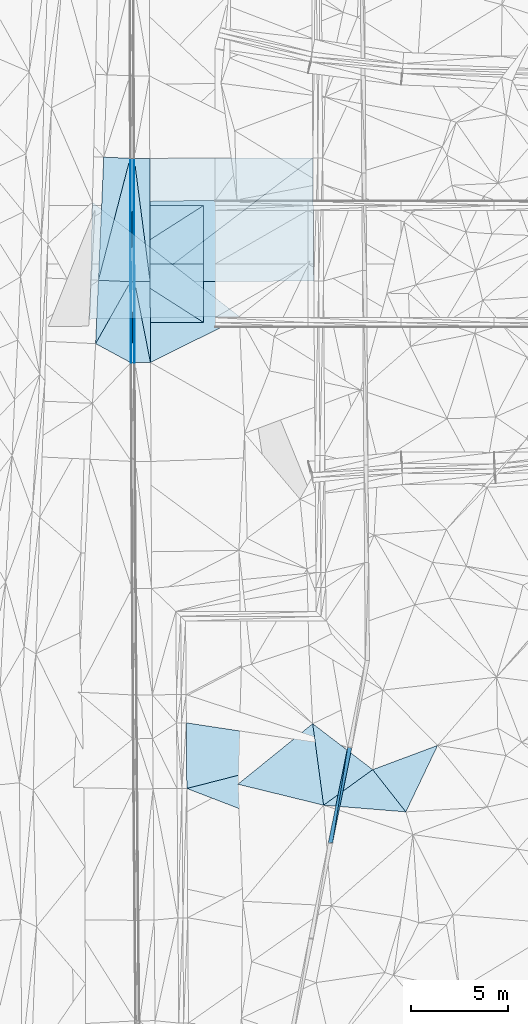
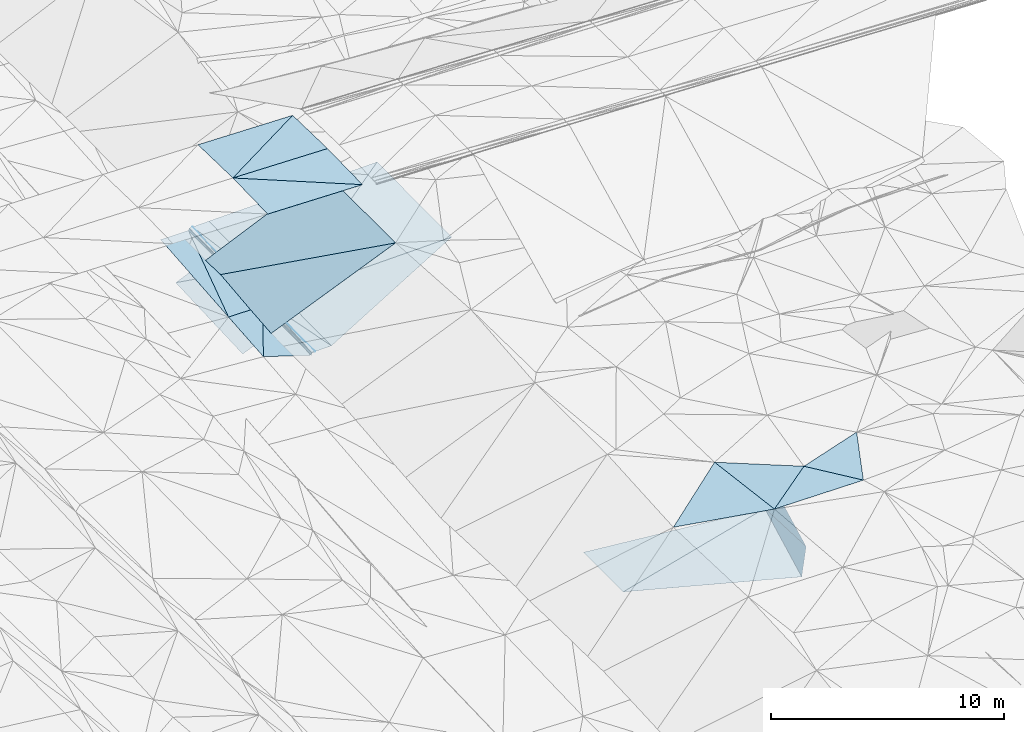
# One storey, part 97 of 275: 37 plates.
"""IFC2X3 building model written with IfcOpenShell, lengths in millimetres."""

from ifc_helpers import new_model, si_unit, frame, origin_with_axes, place, context, subcontext, project, spatial, polyline, outline, extrude, material, type_object, element, save


model = new_model("IFC2X3")

# Units and contexts
model_context = context("Model", 3, precision=1e-05, world=origin_with_axes())
body_context = subcontext(model_context, "Body", "Model", "MODEL_VIEW")
ifc_project = project(units=[si_unit("LENGTHUNIT", "METRE", prefix="MILLI"), si_unit("AREAUNIT", "SQUARE_METRE"), si_unit("VOLUMEUNIT", "CUBIC_METRE"), si_unit("MASSUNIT", "GRAM", prefix="KILO"), si_unit("TIMEUNIT", "SECOND"), si_unit("PLANEANGLEUNIT", "RADIAN"), si_unit("SOLIDANGLEUNIT", "STERADIAN"), si_unit("THERMODYNAMICTEMPERATUREUNIT", "DEGREE_CELSIUS"), si_unit("LUMINOUSINTENSITYUNIT", "LUMEN")], contexts=[model_context])

# Site, building, storey
site_placement = place(None, origin_with_axes())
site = spatial("IfcSite", under=ifc_project, at=site_placement, CompositionType="ELEMENT")
building_placement = place(site_placement, origin_with_axes())
building = spatial("IfcBuilding", under=site, at=building_placement, Name="Undefined", CompositionType="ELEMENT")
storey_placement = place(building_placement, origin_with_axes())
storey = spatial("IfcBuildingStorey", under=building, at=storey_placement, Name="Undefined", CompositionType="ELEMENT", Elevation=0.0)

# Plates
ifc_material = material()
plate_type_1 = type_object("IfcPlateType", PredefinedType="NOTDEFINED")
plate_1_placement = place(storey_placement, frame((-46443.3238897026, 38495.5351845441, 42288.5672650647), z_axis=(0.971991965512378, -0.187664425254864, -0.141469722814266), x_axis=(0.13983122705196, -0.0220094670118286, 0.989930710354517)))
element("IfcPlate", 1, at=plate_1_placement, inside=storey, type_object=plate_type_1, material=ifc_material, Name="00_PR", context=body_context, shape_type="SweptSolid", body=[
    extrude(outline(polyline([(0.0, 0.0), (1515.26257324219, -3.74348019249737e-09), (1212.72692871094, 4952.72412109375), (0.0, 0.0)])), frame((-8.85201319254618e-08, 2.18876761149539e-07, -0.5000001331573), z_axis=(0.0, 0.0, 1.0), x_axis=(1.0, 0.0, 0.0)), (0.0, 0.0, 1.0), 1.0),
])
plate_type_2 = type_object("IfcPlateType", PredefinedType="NOTDEFINED")
plate_2_placement = place(storey_placement, frame((-47435.0792210354, 33594.8791324739, 42010.0176847944), z_axis=(0.97139177371509, -0.188361786243016, -0.144630077929844), x_axis=(0.198043906974716, 0.978613638868407, 0.0556233469949972)))
element("IfcPlate", 2, at=plate_2_placement, inside=storey, type_object=plate_type_2, material=ifc_material, Name="00_PR", context=body_context, shape_type="SweptSolid", body=[
    extrude(outline(polyline([(0.0, 0.0), (5007.75341796875, 1.73531589098275e-09), (138.560333251953, 1513.65197753906), (0.0, 0.0)])), frame((-8.85201319254618e-08, 2.18876761149539e-07, -0.5000001331573), z_axis=(0.0, 0.0, 1.0), x_axis=(1.0, 0.0, 0.0)), (0.0, 0.0, 1.0), 1.0),
])
plate_type_3 = type_object("IfcPlateType", PredefinedType="NOTDEFINED")
plate_3_placement = place(storey_placement, frame((-46443.8034789275, 38495.6560898855, 42288.1387737857), z_axis=(0.0128247435438825, 0.0541554654728636, -0.99845015474607), x_axis=(-0.198043906939524, -0.978613638873617, -0.0556233470286216)))
element("IfcPlate", 3, at=plate_3_placement, inside=storey, type_object=plate_type_3, material=ifc_material, Name="00_PR", context=body_context, shape_type="SweptSolid", body=[
    extrude(outline(polyline([(0.0, 0.0), (5007.75341796875, 1.73531589098275e-09), (3712.27709960938, 7666.49609375), (0.0, 0.0)])), frame((-8.85201319254618e-08, 2.18876761149539e-07, -0.5000001331573), z_axis=(0.0, 0.0, 1.0), x_axis=(1.0, 0.0, 0.0)), (0.0, 0.0, 1.0), 1.0),
])
plate_type_4 = type_object("IfcPlateType", PredefinedType="NOTDEFINED")
plate_4_placement = place(storey_placement, frame((-54717.1743218252, 39751.7977095804, 42114.799182884), z_axis=(0.0230936484077741, 0.0141598385852141, -0.999633023851483), x_axis=(0.988457050789085, -0.150079218943008, 0.0207095820045218)))
element("IfcPlate", 4, at=plate_4_placement, inside=storey, type_object=plate_type_4, material=ifc_material, Name="00_PR", context=body_context, shape_type="SweptSolid", body=[
    extrude(outline(polyline([(0.0, 0.0), (8369.990234375, 2.26027623284608e-08), (528.333984375, 3326.34765625), (0.0, 0.0)])), frame((-8.85201319254618e-08, 2.18876761149539e-07, -0.5000001331573), z_axis=(0.0, 0.0, 1.0), x_axis=(1.0, 0.0, 0.0)), (0.0, 0.0, 1.0), 1.0),
])
plate_type_5 = type_object("IfcPlateType", PredefinedType="NOTDEFINED")
plate_5_placement = place(storey_placement, frame((-57583.1580913611, 62381.0842321567, 42323.0437305526), z_axis=(0.970109415832646, 0.00784634959025921, -0.242541040054978), x_axis=(0.00167557597928032, 0.999236718816342, 0.0390278389651242)))
element("IfcPlate", 5, at=plate_5_placement, inside=storey, type_object=plate_type_5, material=ifc_material, Name="00_PR", context=body_context, shape_type="SweptSolid", body=[
    extrude(outline(polyline([(0.0, 0.0), (6334.068359375, 1.19871401693672e-08), (2.44763946533203, 123.643424987793), (0.0, 0.0)])), frame((-8.85201319254618e-08, 2.18876761149539e-07, -0.5000001331573), z_axis=(0.0, 0.0, 1.0), x_axis=(1.0, 0.0, 0.0)), (0.0, 0.0, 1.0), 1.0),
])
plate_6_placement = place(storey_placement, frame((-57553.1504152899, 62378.7984943262, 42442.993732564), z_axis=(0.970109178269229, 0.00792146438474166, -0.242539548609713), x_axis=(-0.00328523098590343, -0.998946768808441, -0.0457663669581172)))
element("IfcPlate", 6, at=plate_6_placement, inside=storey, type_object=plate_type_5, material=ifc_material, Name="00_PR", context=body_context, shape_type="SweptSolid", body=[
    extrude(outline(polyline([(0.0, 0.0), (4155.2783203125, -3.98358679376543e-09), (3.30489063262939, 123.623481750488), (0.0, 0.0)])), frame((-8.85201319254618e-08, 2.18876761149539e-07, -0.5000001331573), z_axis=(0.0, 0.0, 1.0), x_axis=(1.0, 0.0, 0.0)), (0.0, 0.0, 1.0), 1.0),
])
plate_7_placement = place(storey_placement, frame((-57602.5474534094, 68713.4947868656, 42450.3147632828), z_axis=(0.970125228512707, 0.00784385599563176, -0.242477864817158), x_axis=(0.242600788007672, -0.0256887069750325, 0.969786032066872)))
element("IfcPlate", 7, at=plate_7_placement, inside=storey, type_object=plate_type_5, material=ifc_material, Name="00_PR", context=body_context, shape_type="SweptSolid", body=[
    extrude(outline(polyline([(0.0, 0.0), (123.67057800293, -4.36557456851006e-10), (43.9496803283691, 6333.56640625), (0.0, 0.0)])), frame((-8.85201319254618e-08, 2.18876761149539e-07, -0.5000001331573), z_axis=(0.0, 0.0, 1.0), x_axis=(1.0, 0.0, 0.0)), (0.0, 0.0, 1.0), 1.0),
])
plate_type_6 = type_object("IfcPlateType", PredefinedType="NOTDEFINED")
plate_8_placement = place(storey_placement, frame((-57403.6359865546, 62379.214471116, 42442.6150741335), z_axis=(-4.64282948207224e-05, 0.016925120368047, -0.999856758813452), x_axis=(-0.0321763959872276, -0.999339065058416, -0.0169148629744489)))
element("IfcPlate", 8, at=plate_8_placement, inside=storey, type_object=plate_type_6, material=ifc_material, Name="00_PR", context=body_context, shape_type="SweptSolid", body=[
    extrude(outline(polyline([(0.0, 0.0), (4153.7431640625, 9.57516022026539e-09), (5.23764801025391, 149.908599853516), (0.0, 0.0)])), frame((-8.85201319254618e-08, 2.18876761149539e-07, -0.5000001331573), z_axis=(0.0, 0.0, 1.0), x_axis=(1.0, 0.0, 0.0)), (0.0, 0.0, 1.0), 1.0),
])
plate_9_placement = place(storey_placement, frame((-57423.02381466, 68710.2233984152, 42569.8701035571), z_axis=(1.3473543658177e-05, 0.0200946338517407, -0.999798082369049), x_axis=(-0.0206205769656723, -0.999585493107628, -0.0200906389739794)))
element("IfcPlate", 9, at=plate_9_placement, inside=storey, type_object=plate_type_6, material=ifc_material, Name="00_PR", context=body_context, shape_type="SweptSolid", body=[
    extrude(outline(polyline([(0.0, 0.0), (6334.04443359375, -1.89174897968769e-08), (2.99267792701721, 149.976287841797), (0.0, 0.0)])), frame((-8.85201319254618e-08, 2.18876761149539e-07, -0.5000001331573), z_axis=(0.0, 0.0, 1.0), x_axis=(1.0, 0.0, 0.0)), (0.0, 0.0, 1.0), 1.0),
])
plate_10_placement = place(storey_placement, frame((-57553.6354985413, 62378.8045805824, 42442.615103797), z_axis=(-5.51267280488613e-05, 0.0200960484179308, -0.999798052508119), x_axis=(0.0206205769630277, 0.999585493107631, 0.0200906389765653)))
element("IfcPlate", 10, at=plate_10_placement, inside=storey, type_object=plate_type_6, material=ifc_material, Name="00_PR", context=body_context, shape_type="SweptSolid", body=[
    extrude(outline(polyline([(0.0, 0.0), (6334.04443359375, -1.89174897968769e-08), (3.50438213348389, 149.959136962891), (0.0, 0.0)])), frame((-8.85201319254618e-08, 2.18876761149539e-07, -0.5000001331573), z_axis=(0.0, 0.0, 1.0), x_axis=(1.0, 0.0, 0.0)), (0.0, 0.0, 1.0), 1.0),
])
plate_11_placement = place(storey_placement, frame((-57537.2884837733, 58228.2164305022, 42372.3550744703), z_axis=(-5.15273774666968e-05, 0.0169252844974001, -0.999856755785353), x_axis=(0.0321763959547341, 0.999339065059428, 0.0169148629764597)))
element("IfcPlate", 11, at=plate_11_placement, inside=storey, type_object=plate_type_6, material=ifc_material, Name="00_PR", context=body_context, shape_type="SweptSolid", body=[
    extrude(outline(polyline([(0.0, 0.0), (4153.7431640625, 9.57516022026539e-09), (5.28282499313354, 149.907943725586), (0.0, 0.0)])), frame((-8.85201319254618e-08, 2.18876761149539e-07, -0.5000001331573), z_axis=(0.0, 0.0, 1.0), x_axis=(1.0, 0.0, 0.0)), (0.0, 0.0, 1.0), 1.0),
])
plate_type_7 = type_object("IfcPlateType", PredefinedType="NOTDEFINED")
plate_12_placement = place(storey_placement, frame((-57393.0137184063, 68710.2992671655, 42570.4702018794), z_axis=(0.0199409265172803, 0.0201533647620277, -0.99959801987519), x_axis=(0.00306177402900717, -0.999793362311022, -0.0200962239890106)))
element("IfcPlate", 12, at=plate_12_placement, inside=storey, type_object=plate_type_7, material=ifc_material, Name="00_PR", context=body_context, shape_type="SweptSolid", body=[
    extrude(outline(polyline([(0.0, 0.0), (6332.2841796875, -4.51836967840791e-09), (-0.00397421419620514, 30.0062274932861), (0.0, 0.0)])), frame((-8.85201319254618e-08, 2.18876761149539e-07, -0.5000001331573), z_axis=(0.0, 0.0, 1.0), x_axis=(1.0, 0.0, 0.0)), (0.0, 0.0, 1.0), 1.0),
])
plate_13_placement = place(storey_placement, frame((-57373.6257019112, 62379.3221283194, 42443.2151726145), z_axis=(0.0199319540919098, 0.0170006912218534, -0.999656787954775), x_axis=(0.00393805502764794, -0.999848999201306, -0.0169254399867523)))
element("IfcPlate", 13, at=plate_13_placement, inside=storey, type_object=plate_type_7, material=ifc_material, Name="00_PR", context=body_context, shape_type="SweptSolid", body=[
    extrude(outline(polyline([(0.0, 0.0), (4151.1474609375, 2.19733919948339e-09), (-0.000386318599339575, 30.0064868927002), (0.0, 0.0)])), frame((-8.85201319254618e-08, 2.18876761149539e-07, -0.5000001331573), z_axis=(0.0, 0.0, 1.0), x_axis=(1.0, 0.0, 0.0)), (0.0, 0.0, 1.0), 1.0),
])
plate_14_placement = place(storey_placement, frame((-57403.6260058779, 62379.2160860442, 42442.6152035022), z_axis=(0.0199197102945719, 0.0201533083165192, -0.999598444029241), x_axis=(-0.00306177403052617, 0.999793362310987, 0.0200962239905203)))
element("IfcPlate", 14, at=plate_14_placement, inside=storey, type_object=plate_type_7, material=ifc_material, Name="00_PR", context=body_context, shape_type="SweptSolid", body=[
    extrude(outline(polyline([(0.0, 0.0), (6332.31591796875, 6.03904481977224e-10), (0.0278000384569168, 30.0064754486084), (0.0, 0.0)])), frame((-8.85201319254618e-08, 2.18876761149539e-07, -0.5000001331573), z_axis=(0.0, 0.0, 1.0), x_axis=(1.0, 0.0, 0.0)), (0.0, 0.0, 1.0), 1.0),
])
plate_15_placement = place(storey_placement, frame((-57387.2781938566, 58228.6731262315, 42372.3551743168), z_axis=(0.0199204725202809, 0.0170006498874618, -0.999657017520496), x_axis=(-0.00393805503277825, 0.999848999201264, 0.0169254399880597)))
element("IfcPlate", 15, at=plate_15_placement, inside=storey, type_object=plate_type_7, material=ifc_material, Name="00_PR", context=body_context, shape_type="SweptSolid", body=[
    extrude(outline(polyline([(0.0, 0.0), (4151.16796875, 1.2019881978631e-08), (0.0202217120677233, 30.006196975708), (0.0, 0.0)])), frame((-8.85201319254618e-08, 2.18876761149539e-07, -0.5000001331573), z_axis=(0.0, 0.0, 1.0), x_axis=(1.0, 0.0, 0.0)), (0.0, 0.0, 1.0), 1.0),
])
plate_type_8 = type_object("IfcPlateType", PredefinedType="NOTDEFINED")
plate_16_placement = place(storey_placement, frame((-57603.0168962329, 68713.5009297058, 42449.9363460204), z_axis=(0.0312264402809084, 0.0201291176493456, -0.999309625716695), x_axis=(-0.251028639082119, -0.967593640171282, -0.0273344079991938)))
element("IfcPlate", 16, at=plate_16_placement, inside=storey, type_object=plate_type_8, material=ifc_material, Name="00_PR", context=body_context, shape_type="SweptSolid", body=[
    extrude(outline(polyline([(0.0, 0.0), (6468.66015625, -3.15776560455561e-09), (284.202697753906, 1322.8330078125), (0.0, 0.0)])), frame((-8.85201319254618e-08, 2.18876761149539e-07, -0.5000001331573), z_axis=(0.0, 0.0, 1.0), x_axis=(1.0, 0.0, 0.0)), (0.0, 0.0, 1.0), 1.0),
])
plate_type_9 = type_object("IfcPlateType", PredefinedType="NOTDEFINED")
plate_17_placement = place(storey_placement, frame((-59226.8359766766, 62454.4664118269, 42273.1193435285), z_axis=(0.0310324259714085, 0.0201795939242266, -0.999314651412348), x_axis=(0.25102863907814, 0.967593640172316, 0.0273344079991539)))
element("IfcPlate", 17, at=plate_17_placement, inside=storey, type_object=plate_type_9, material=ifc_material, Name="00_PR", context=body_context, shape_type="SweptSolid", body=[
    extrude(outline(polyline([(0.0, 0.0), (6468.66015625, -3.15776560455561e-09), (342.848510742188, 1609.48046875), (0.0, 0.0)])), frame((-8.85201319254618e-08, 2.18876761149539e-07, -0.5000001331573), z_axis=(0.0, 0.0, 1.0), x_axis=(1.0, 0.0, 0.0)), (0.0, 0.0, 1.0), 1.0),
])
plate_type_10 = type_object("IfcPlateType", PredefinedType="NOTDEFINED")
plate_18_placement = place(storey_placement, frame((-57583.627696025, 62381.0888398174, 42322.6653124448), z_axis=(0.0308951552232483, 0.0170634038894143, -0.999376970732985), x_axis=(-0.490203292960482, -0.871090745870499, -0.0300273879896106)))
element("IfcPlate", 18, at=plate_18_placement, inside=storey, type_object=plate_type_10, material=ifc_material, Name="00_PR", context=body_context, shape_type="SweptSolid", body=[
    extrude(outline(polyline([(0.0, 0.0), (3648.26953125, -7.97444954514503e-09), (743.076721191406, 1468.267578125), (0.0, 0.0)])), frame((-8.85201319254618e-08, 2.18876761149539e-07, -0.5000001331573), z_axis=(0.0, 0.0, 1.0), x_axis=(1.0, 0.0, 0.0)), (0.0, 0.0, 1.0), 1.0),
])
plate_type_11 = type_object("IfcPlateType", PredefinedType="NOTDEFINED")
plate_19_placement = place(storey_placement, frame((-48224.0877429359, 68733.5261889492, 42753.8472018296), z_axis=(0.0199193965717795, 0.0201840669271931, -0.999597829670761), x_axis=(0.00717806702355623, -0.999773319631286, -0.0200445680233559)))
element("IfcPlate", 19, at=plate_19_placement, inside=storey, type_object=plate_type_11, material=ifc_material, Name="00_PR", context=body_context, shape_type="SweptSolid", body=[
    extrude(outline(polyline([(0.0, 0.0), (6322.611328125, 2.99114617519081e-08), (6295.85986328125, 8396.619140625), (0.0, 0.0)])), frame((-8.85201319254618e-08, 2.18876761149539e-07, -0.5000001331573), z_axis=(0.0, 0.0, 1.0), x_axis=(1.0, 0.0, 0.0)), (0.0, 0.0, 1.0), 1.0),
])
plate_type_12 = type_object("IfcPlateType", PredefinedType="NOTDEFINED")
plate_20_placement = place(storey_placement, frame((-56593.0162378937, 68712.3262125957, 42586.4702020143), z_axis=(0.0199409537790838, 0.0201560509080303, -0.999597965171085), x_axis=(0.00306180399194172, -0.999793308226059, -0.0200989099880669)))
element("IfcPlate", 20, at=plate_20_placement, inside=storey, type_object=plate_type_12, material=ifc_material, Name="00_PR", context=body_context, shape_type="SweptSolid", body=[
    extrude(outline(polyline([(0.0, 0.0), (6331.43798828125, -4.45434125140309e-08), (-0.101329416036606, 800.160034179688), (0.0, 0.0)])), frame((-8.85201319254618e-08, 2.18876761149539e-07, -0.5000001331573), z_axis=(0.0, 0.0, 1.0), x_axis=(1.0, 0.0, 0.0)), (0.0, 0.0, 1.0), 1.0),
])
plate_21_placement = place(storey_placement, frame((-56573.6306226574, 62382.1953694276, 42459.2151729288), z_axis=(0.0199321903594171, 0.0170029528414679, -0.999656744779), x_axis=(0.00393791499498568, -0.999848961425214, -0.0169277039911789)))
element("IfcPlate", 21, at=plate_21_placement, inside=storey, type_object=plate_type_12, material=ifc_material, Name="00_PR", context=body_context, shape_type="SweptSolid", body=[
    extrude(outline(polyline([(0.0, 0.0), (4150.59228515625, 1.087028067559e-08), (-0.00666399206966162, 800.160217285156), (0.0, 0.0)])), frame((-8.85201319254618e-08, 2.18876761149539e-07, -0.5000001331573), z_axis=(0.0, 0.0, 1.0), x_axis=(1.0, 0.0, 0.0)), (0.0, 0.0, 1.0), 1.0),
])
plate_22_placement = place(storey_placement, frame((-57373.6257084057, 62379.3237044941, 42443.2152018937), z_axis=(0.0199197102945719, 0.0201533083165192, -0.999598444029241), x_axis=(-0.00306177403052617, 0.999793362310987, 0.0200962239905203)))
element("IfcPlate", 22, at=plate_22_placement, inside=storey, type_object=plate_type_12, material=ifc_material, Name="00_PR", context=body_context, shape_type="SweptSolid", body=[
    extrude(outline(polyline([(0.0, 0.0), (6332.2841796875, -4.51836967840791e-09), (0.744781196117401, 800.159851074219), (0.0, 0.0)])), frame((-8.85201319254618e-08, 2.18876761149539e-07, -0.5000001331573), z_axis=(0.0, 0.0, 1.0), x_axis=(1.0, 0.0, 0.0)), (0.0, 0.0, 1.0), 1.0),
])
plate_23_placement = place(storey_placement, frame((-57357.2782605059, 58228.8013939178, 42372.955173437), z_axis=(0.0199204725202809, 0.0170006498874618, -0.999657017520496), x_axis=(-0.00393805503277825, 0.999848999201264, 0.0169254399880597)))
element("IfcPlate", 23, at=plate_23_placement, inside=storey, type_object=plate_type_12, material=ifc_material, Name="00_PR", context=body_context, shape_type="SweptSolid", body=[
    extrude(outline(polyline([(0.0, 0.0), (4151.1474609375, 2.19733919948339e-09), (0.548414885997772, 800.159423828125), (0.0, 0.0)])), frame((-8.85201319254618e-08, 2.18876761149539e-07, -0.5000001331573), z_axis=(0.0, 0.0, 1.0), x_axis=(1.0, 0.0, 0.0)), (0.0, 0.0, 1.0), 1.0),
])
plate_type_13 = type_object("IfcPlateType", PredefinedType="NOTDEFINED")
plate_24_placement = place(storey_placement, frame((-56573.6306182186, 62382.1969456075, 42459.2152024262), z_axis=(0.0199409537790838, 0.0201560509080303, -0.999597965171085), x_axis=(-0.00306180399060174, 0.999793308225989, 0.0200989099917165)))
element("IfcPlate", 24, at=plate_24_placement, inside=storey, type_object=plate_type_13, material=ifc_material, Name="00_PR", context=body_context, shape_type="SweptSolid", body=[
    extrude(outline(polyline([(0.0, 0.0), (6331.43798828125, -4.45434125140309e-08), (6330.37353515625, 8370.62890625), (0.0, 0.0)])), frame((-8.85201319254618e-08, 2.18876761149539e-07, -0.5000001331573), z_axis=(0.0, 0.0, 1.0), x_axis=(1.0, 0.0, 0.0)), (0.0, 0.0, 1.0), 1.0),
])
plate_type_14 = type_object("IfcPlateType", PredefinedType="NOTDEFINED")
plate_25_placement = place(storey_placement, frame((-56557.285949707, 58232.2299351179, 42388.955173764), z_axis=(0.0199321903594171, 0.0170029528414679, -0.999656744779), x_axis=(-0.00393791499492784, 0.999848961425225, 0.0169277039905461)))
element("IfcPlate", 25, at=plate_25_placement, inside=storey, type_object=plate_type_14, material=ifc_material, Name="00_PR", context=body_context, shape_type="SweptSolid", body=[
    extrude(outline(polyline([(0.0, 0.0), (4150.59228515625, 1.087028067559e-08), (4150.5224609375, 8396.6611328125), (0.0, 0.0)])), frame((-8.85201319254618e-08, 2.18876761149539e-07, -0.5000001331573), z_axis=(0.0, 0.0, 1.0), x_axis=(1.0, 0.0, 0.0)), (0.0, 0.0, 1.0), 1.0),
])
plate_type_15 = type_object("IfcPlateType", PredefinedType="NOTDEFINED")
plate_26_placement = place(storey_placement, frame((-57566.8014832062, 58227.8964699172, 42252.8216508506), z_axis=(0.970068887504394, 0.00792896632504802, -0.242700401707544), x_axis=(0.00328523097400701, 0.998946768808269, 0.0457663669627169)))
element("IfcPlate", 26, at=plate_26_placement, inside=storey, type_object=plate_type_15, material=ifc_material, Name="00_PR", context=body_context, shape_type="SweptSolid", body=[
    extrude(outline(polyline([(0.0, 0.0), (4155.2783203125, -3.98358679376543e-09), (5.90161895751953, 123.466766357422), (0.0, 0.0)])), frame((-8.85201319254618e-08, 2.18876761149539e-07, -0.5000001331573), z_axis=(0.0, 0.0, 1.0), x_axis=(1.0, 0.0, 0.0)), (0.0, 0.0, 1.0), 1.0),
])
plate_type_16 = type_object("IfcPlateType", PredefinedType="NOTDEFINED")
plate_27_placement = place(storey_placement, frame((-59372.0213496095, 59203.1150807108, 42213.117313471), z_axis=(0.0309732534183752, 0.0170193969162361, -0.999375303727928), x_axis=(0.490203292900548, 0.87109074590492, 0.0300273879694712)))
element("IfcPlate", 27, at=plate_27_placement, inside=storey, type_object=plate_type_16, material=ifc_material, Name="00_PR", context=body_context, shape_type="SweptSolid", body=[
    extrude(outline(polyline([(0.0, 0.0), (3648.26953125, -7.97444954514503e-09), (36.3754577636719, 2051.43603515625), (0.0, 0.0)])), frame((-8.85201319254618e-08, 2.18876761149539e-07, -0.5000001331573), z_axis=(0.0, 0.0, 1.0), x_axis=(1.0, 0.0, 0.0)), (0.0, 0.0, 1.0), 1.0),
])
plate_type_17 = type_object("IfcPlateType", PredefinedType="NOTDEFINED")
plate_28_placement = place(storey_placement, frame((-48234.3248582751, 39707.5063014701, 44599.5003780371), z_axis=(0.0232287825678581, 0.0317789676541117, -0.999224960094199), x_axis=(0.132308295687403, -0.990800660378434, -0.0284352999976238)))
element("IfcPlate", 28, at=plate_28_placement, inside=storey, type_object=plate_type_17, material=ifc_material, Name="00", context=body_context, shape_type="SweptSolid", body=[
    extrude(outline(polyline([(0.0, 0.0), (4220.1064453125, 3.5579432733357e-09), (2575.02734375, 4216.7353515625), (0.0, 0.0)])), frame((-8.85201319254618e-08, 2.18876761149539e-07, -0.5000001331573), z_axis=(0.0, 0.0, 1.0), x_axis=(1.0, 0.0, 0.0)), (0.0, 0.0, 1.0), 1.0),
])
plate_type_18 = type_object("IfcPlateType", PredefinedType="NOTDEFINED")
plate_29_placement = place(storey_placement, frame((-53830.6175532002, 60289.9876185834, 48643.3932715736), z_axis=(-0.0216235629478201, 0.0249875852652809, -0.999453871926089), x_axis=(-0.9997660047005, 5.73109808275144e-05, 0.0216317489041162)))
element("IfcPlate", 29, at=plate_29_placement, inside=storey, type_object=plate_type_18, material=ifc_material, Name="00_PR", context=body_context, shape_type="SweptSolid", body=[
    extrude(outline(polyline([(0.0, 0.0), (4701.09912109375, -1.42754288390279e-08), (4702.7216796875, 3000.93701171875), (0.0, 0.0)])), frame((-8.85201319254618e-08, 2.18876761149539e-07, -0.5000001331573), z_axis=(0.0, 0.0, 1.0), x_axis=(1.0, 0.0, 0.0)), (0.0, 0.0, 1.0), 1.0),
])
plate_30_placement = place(storey_placement, frame((-53830.2737874718, 66289.9626745604, 48643.38127137), z_axis=(-0.0216264198537467, -0.0249891132362438, -0.999453771909424), x_axis=(-5.69709776589813e-05, -0.999687544781834, 0.0249961909573564)))
element("IfcPlate", 30, at=plate_30_placement, inside=storey, type_object=plate_type_18, material=ifc_material, Name="00_PR", context=body_context, shape_type="SweptSolid", body=[
    extrude(outline(polyline([(0.0, 0.0), (3000.93725585938, 4.2564352042973e-09), (3003.47802734375, 4701.099609375), (0.0, 0.0)])), frame((-8.85201319254618e-08, 2.18876761149539e-07, -0.5000001331573), z_axis=(0.0, 0.0, 1.0), x_axis=(1.0, 0.0, 0.0)), (0.0, 0.0, 1.0), 1.0),
])
plate_31_placement = place(storey_placement, frame((-58530.4448933996, 63290.2320772299, 48820.0862706522), z_axis=(-0.0216289778686254, -0.0249851060489526, -0.999453816737963), x_axis=(5.72779774420735e-05, 0.999687644773175, -0.0249921909222736)))
element("IfcPlate", 31, at=plate_31_placement, inside=storey, type_object=plate_type_18, material=ifc_material, Name="00_PR", context=body_context, shape_type="SweptSolid", body=[
    extrude(outline(polyline([(0.0, 0.0), (3000.9375, -1.02954800240695e-08), (3003.47900390625, 4701.0986328125), (0.0, 0.0)])), frame((-8.85201319254618e-08, 2.18876761149539e-07, -0.5000001331573), z_axis=(0.0, 0.0, 1.0), x_axis=(1.0, 0.0, 0.0)), (0.0, 0.0, 1.0), 1.0),
])
plate_32_placement = place(storey_placement, frame((-58530.4448894081, 63290.257063013, 48820.0862700876), z_axis=(-0.0216235629478201, 0.0249875852652809, -0.999453871926089), x_axis=(0.999766004791673, -5.72249672264926e-05, -0.0216317449180733)))
element("IfcPlate", 32, at=plate_32_placement, inside=storey, type_object=plate_type_18, material=ifc_material, Name="00_PR", context=body_context, shape_type="SweptSolid", body=[
    extrude(outline(polyline([(0.0, 0.0), (4701.10009765625, -4.32919478043914e-09), (4702.7216796875, 3000.93725585938), (0.0, 0.0)])), frame((-8.85201319254618e-08, 2.18876761149539e-07, -0.5000001331573), z_axis=(0.0, 0.0, 1.0), x_axis=(1.0, 0.0, 0.0)), (0.0, 0.0, 1.0), 1.0),
])
plate_type_19 = type_object("IfcPlateType", PredefinedType="NOTDEFINED")
plate_33_placement = place(storey_placement, frame((-45158.3614580886, 37349.9244605366, 44739.5017708189), z_axis=(0.0749414715225941, 0.0386045971552393, -0.996440395068621), x_axis=(-0.807029374037931, -0.584600049797598, -0.083344893164443)))
element("IfcPlate", 33, at=plate_33_placement, inside=storey, type_object=plate_type_19, material=ifc_material, Name="00", context=body_context, shape_type="SweptSolid", body=[
    extrude(outline(polyline([(0.0, 0.0), (3119.5673828125, -6.73753675073385e-09), (1115.79577636719, 3714.05444335938), (0.0, 0.0)])), frame((-8.85201319254618e-08, 2.18876761149539e-07, -0.5000001331573), z_axis=(0.0, 0.0, 1.0), x_axis=(1.0, 0.0, 0.0)), (0.0, 0.0, 1.0), 1.0),
])
plate_type_20 = type_object("IfcPlateType", PredefinedType="NOTDEFINED")
plate_34_placement = place(storey_placement, frame((-43456.8844468051, 35182.8476281367, 44729.5003445861), z_axis=(-0.031486051286057, -0.0201109817768694, -0.999301844782838), x_axis=(-0.617559407475955, 0.786515864710005, 0.00362943486245786)))
element("IfcPlate", 34, at=plate_34_placement, inside=storey, type_object=plate_type_20, material=ifc_material, Name="00", context=body_context, shape_type="SweptSolid", body=[
    extrude(outline(polyline([(0.0, 0.0), (2755.24951171875, -3.81623976863921e-09), (1675.12963867188, 3390.69921875), (0.0, 0.0)])), frame((-8.85201319254618e-08, 2.18876761149539e-07, -0.5000001331573), z_axis=(0.0, 0.0, 1.0), x_axis=(1.0, 0.0, 0.0)), (0.0, 0.0, 1.0), 1.0),
])
plate_type_21 = type_object("IfcPlateType", PredefinedType="NOTDEFINED")
plate_35_placement = place(storey_placement, frame((-45158.3671905499, 37349.9323780998, 44739.501742169), z_axis=(0.0634768591857049, 0.0544394027824093, -0.996497385732955), x_axis=(0.617559407533786, -0.786515864664373, -0.00362943491088941)))
element("IfcPlate", 35, at=plate_35_placement, inside=storey, type_object=plate_type_21, material=ifc_material, Name="00", context=body_context, shape_type="SweptSolid", body=[
    extrude(outline(polyline([(0.0, 0.0), (2755.24951171875, -3.81623976863921e-09), (-119.444717407227, 3117.27978515625), (0.0, 0.0)])), frame((-8.85201319254618e-08, 2.18876761149539e-07, -0.5000001331573), z_axis=(0.0, 0.0, 1.0), x_axis=(1.0, 0.0, 0.0)), (0.0, 0.0, 1.0), 1.0),
])
plate_type_22 = type_object("IfcPlateType", PredefinedType="NOTDEFINED")
plate_36_placement = place(storey_placement, frame((-59679.3416493134, 60454.3327002412, 41700.5354971406), z_axis=(0.370105448989261, -0.000321918941484266, -0.928989694774196), x_axis=(0.0238529934506408, 0.999673543172083, 0.00915651599774429)))
element("IfcPlate", 36, at=plate_36_placement, inside=storey, type_object=plate_type_22, material=ifc_material, Name="00", context=body_context, shape_type="SweptSolid", body=[
    extrude(outline(polyline([(0.0, 0.0), (6006.6513671875, 2.77359504252672e-08), (358.330108642578, 8256.1689453125), (0.0, 0.0)])), frame((-8.85201319254618e-08, 2.18876761149539e-07, -0.5000001331573), z_axis=(0.0, 0.0, 1.0), x_axis=(1.0, 0.0, 0.0)), (0.0, 0.0, 1.0), 1.0),
])
plate_type_23 = type_object("IfcPlateType", PredefinedType="NOTDEFINED")
plate_37_placement = place(storey_placement, frame((-52122.4573933269, 66578.9168843748, 44922.5403461704), z_axis=(0.392178128772029, 0.0330334102353442, -0.919295985589567), x_axis=(0.0199042345830939, -0.999425777678308, -0.0274214579803929)))
element("IfcPlate", 37, at=plate_37_placement, inside=storey, type_object=plate_type_23, material=ifc_material, Name="00", context=body_context, shape_type="SweptSolid", body=[
    extrude(outline(polyline([(0.0, 0.0), (5980.7177734375, 1.45737431012094e-08), (59.0898971557617, 8062.39306640625), (0.0, 0.0)])), frame((-8.85201319254618e-08, 2.18876761149539e-07, -0.5000001331573), z_axis=(0.0, 0.0, 1.0), x_axis=(1.0, 0.0, 0.0)), (0.0, 0.0, 1.0), 1.0),
])

save(model, "model.ifc")
